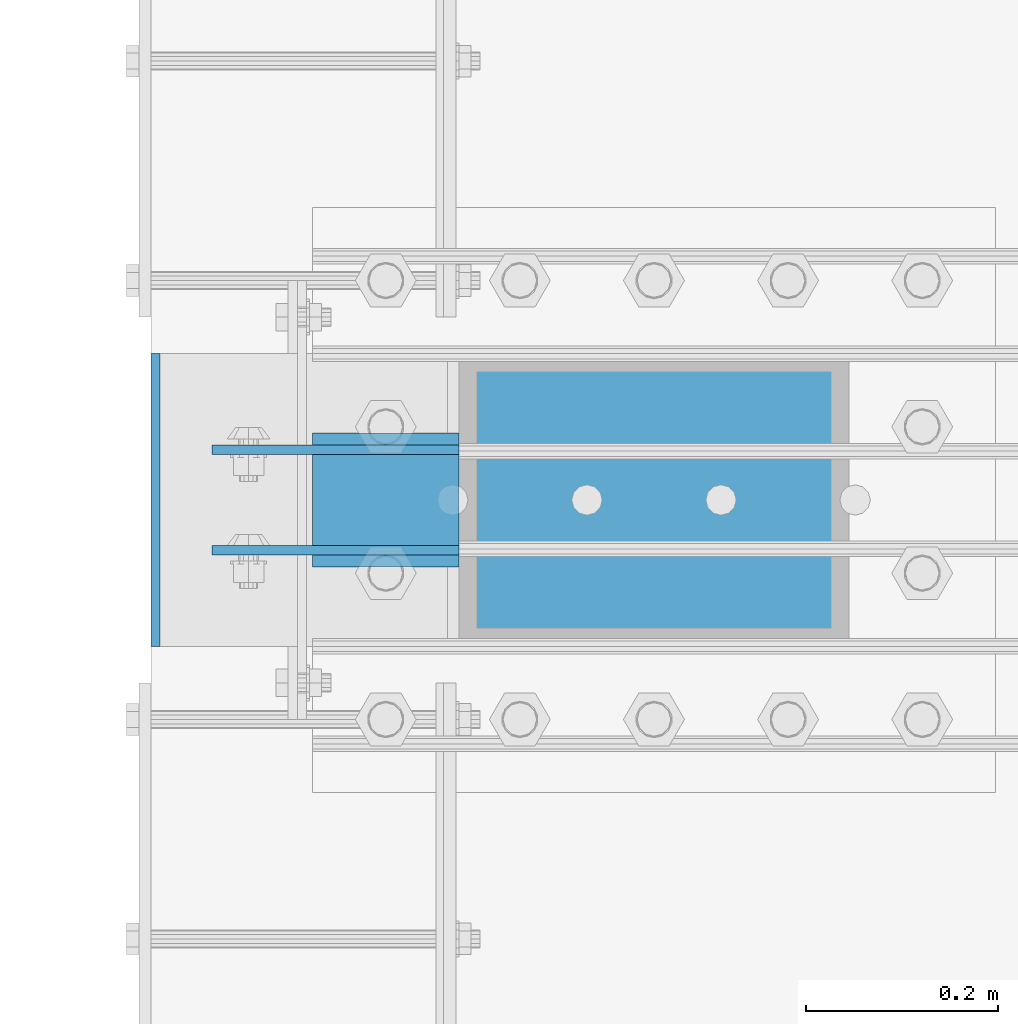
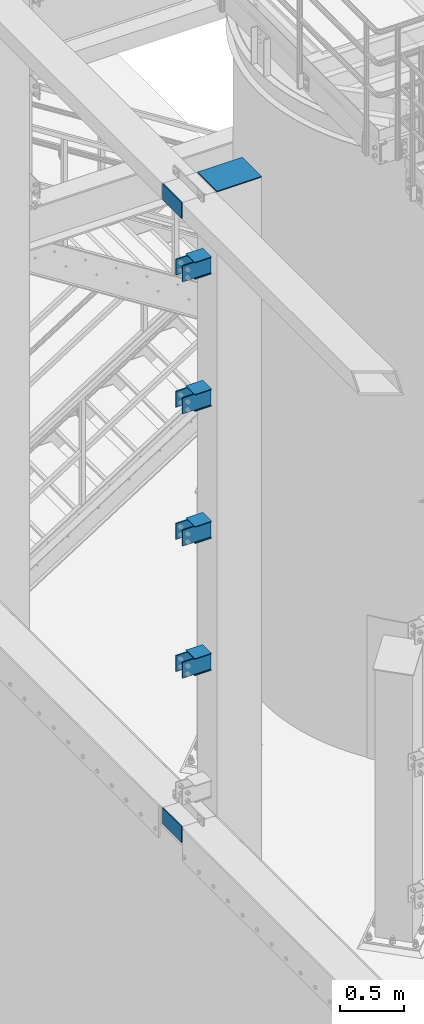
# One storey, part 1096 of 1876: 19 beams, 1 element without a shape of its own.
"""IFC2X3 building model written with IfcOpenShell, lengths in millimetres."""

from ifc_helpers import new_model, si_unit, frame, origin_with_axes, place, context, subcontext, project, spatial, faceted_brep, material, type_object, element, aggregate, save


model = new_model("IFC2X3")

# Units and contexts
model_context = context("Model", 3, precision=1e-05, world=origin_with_axes())
body_context = subcontext(model_context, "Body", "Model", "MODEL_VIEW")
ifc_project = project(units=[si_unit("LENGTHUNIT", "METRE", prefix="MILLI"), si_unit("AREAUNIT", "SQUARE_METRE"), si_unit("VOLUMEUNIT", "CUBIC_METRE"), si_unit("MASSUNIT", "GRAM", prefix="KILO"), si_unit("TIMEUNIT", "SECOND"), si_unit("PLANEANGLEUNIT", "RADIAN"), si_unit("SOLIDANGLEUNIT", "STERADIAN"), si_unit("THERMODYNAMICTEMPERATUREUNIT", "DEGREE_CELSIUS"), si_unit("LUMINOUSINTENSITYUNIT", "LUMEN")], contexts=[model_context])

# Site, building, storey
site_placement = place(None, origin_with_axes())
site = spatial("IfcSite", under=ifc_project, at=site_placement, CompositionType="ELEMENT")
building_placement = place(site_placement, origin_with_axes())
building = spatial("IfcBuilding", under=site, at=building_placement, Name="Undefined", CompositionType="ELEMENT")
storey_placement = place(building_placement, origin_with_axes())
storey = spatial("IfcBuildingStorey", under=building, at=storey_placement, Name="Undefined", CompositionType="ELEMENT", Elevation=0.0)

# Assembly, beams
assembly_placement = place(storey_placement, origin_with_axes())
assembly = element("IfcElementAssembly", 1, at=assembly_placement, inside=storey, Name="COLUMN", AssemblyPlace="NOTDEFINED", PredefinedType="RIGID_FRAME")
ifc_material = material(Name="STEEL/A36")
beam_type_1 = type_object("IfcBeamType", PredefinedType="NOTDEFINED")
beam_1_placement = place(assembly_placement, frame((28.5750000000013, -14479.5875, 6097.5875), z_axis=(0.0, 0.0, -1.0), x_axis=(-1.0, 0.0, 0.0)))
beam_1 = element("IfcBeam", 2, at=beam_1_placement, type_object=beam_type_1, material=ifc_material, Name="PLATE", context=body_context, shape_type="Brep", body=[
    faceted_brep([(0.0, 4.76249999999982, -76.1999999999998), (3.63797880709171e-12, 4.76249999999982, 76.1999969482422), (257.174999999999, 4.76249999999982, 76.1999999999998), (257.174999999999, 4.76249999999982, -76.1999999999998), (3.63797880709171e-12, -4.76249999999982, 76.1999969482422), (257.174999999999, -4.76249999999982, 76.1999999999998), (0.0, -4.76249999999982, -76.1999999999998), (257.174999999999, -4.76249999999982, -76.1999999999998)], [[[0, 1, 2, 3]], [[1, 4, 5, 2]], [[4, 6, 7, 5]], [[6, 0, 3, 7]], [[5, 7, 3, 2]], [[6, 4, 1, 0]]]),
])
beam_2_placement = place(assembly_placement, frame((28.5750000000013, -14479.5875, 7366.46302033333), z_axis=(0.0, 0.0, -1.0), x_axis=(-1.0, 0.0, 0.0)))
beam_2 = element("IfcBeam", 3, at=beam_2_placement, type_object=beam_type_1, material=ifc_material, Name="PLATE", context=body_context, shape_type="Brep", body=[
    faceted_brep([(0.0, 4.76249999999982, -76.1999999999998), (3.63797880709171e-12, 4.76249999999982, 76.1999969482422), (257.174999999999, 4.76249999999982, 76.1999999999998), (257.174999999999, 4.76249999999982, -76.1999999999998), (3.63797880709171e-12, -4.76249999999982, 76.1999969482422), (257.174999999999, -4.76249999999982, 76.1999999999998), (0.0, -4.76249999999982, -76.1999999999998), (257.174999999999, -4.76249999999982, -76.1999999999998)], [[[0, 1, 2, 3]], [[1, 4, 5, 2]], [[4, 6, 7, 5]], [[6, 0, 3, 7]], [[5, 7, 3, 2]], [[6, 4, 1, 0]]]),
])
beam_3_placement = place(assembly_placement, frame((28.5750000000013, -14479.5875, 8635.47083333333), z_axis=(0.0, 0.0, -1.0), x_axis=(-1.0, 0.0, 0.0)))
beam_3 = element("IfcBeam", 4, at=beam_3_placement, type_object=beam_type_1, material=ifc_material, Name="PLATE", context=body_context, shape_type="Brep", body=[
    faceted_brep([(0.0, 4.76249999999982, -76.1999999999998), (3.63797880709171e-12, 4.76249999999982, 76.1999969482422), (257.174999999999, 4.76249999999982, 76.1999999999998), (257.174999999999, 4.76249999999982, -76.1999999999998), (3.63797880709171e-12, -4.76249999999982, 76.1999969482422), (257.174999999999, -4.76249999999982, 76.1999999999998), (0.0, -4.76249999999982, -76.1999999999998), (257.174999999999, -4.76249999999982, -76.1999999999998)], [[[0, 1, 2, 3]], [[1, 4, 5, 2]], [[4, 6, 7, 5]], [[6, 0, 3, 7]], [[5, 7, 3, 2]], [[6, 4, 1, 0]]]),
])
beam_4_placement = place(assembly_placement, frame((28.5750000000013, -14479.5875, 9904.4125), z_axis=(0.0, 0.0, -1.0), x_axis=(-1.0, 0.0, 0.0)))
beam_4 = element("IfcBeam", 5, at=beam_4_placement, type_object=beam_type_1, material=ifc_material, Name="PLATE", context=body_context, shape_type="Brep", body=[
    faceted_brep([(0.0, 4.76249999999982, -76.1999999999998), (3.63797880709171e-12, 4.76249999999982, 76.1999969482422), (257.174999999999, 4.76249999999982, 76.1999999999998), (257.174999999999, 4.76249999999982, -76.1999999999998), (3.63797880709171e-12, -4.76249999999982, 76.1999969482422), (257.174999999999, -4.76249999999982, 76.1999999999998), (0.0, -4.76249999999982, -76.1999999999998), (257.174999999999, -4.76249999999982, -76.1999999999998)], [[[0, 1, 2, 3]], [[1, 4, 5, 2]], [[4, 6, 7, 5]], [[6, 0, 3, 7]], [[5, 7, 3, 2]], [[6, 4, 1, 0]]]),
])
beam_5_placement = place(assembly_placement, frame((28.5750000000013, -14374.8124984741, 6097.5875), z_axis=(0.0, 0.0, -1.0), x_axis=(-1.0, 0.0, 0.0)))
beam_5 = element("IfcBeam", 6, at=beam_5_placement, type_object=beam_type_1, material=ifc_material, Name="PLATE", context=body_context, shape_type="Brep", body=[
    faceted_brep([(0.0, 4.76249999999982, -76.1999999999998), (3.63797880709171e-12, 4.76249999999982, 76.1999969482422), (257.174999999999, 4.76249999999982, 76.1999999999998), (257.174999999999, 4.76249999999982, -76.1999999999998), (3.63797880709171e-12, -4.76249999999982, 76.1999969482422), (257.174999999999, -4.76249999999982, 76.1999999999998), (0.0, -4.76249999999982, -76.1999999999998), (257.174999999999, -4.76249999999982, -76.1999999999998)], [[[0, 1, 2, 3]], [[1, 4, 5, 2]], [[4, 6, 7, 5]], [[6, 0, 3, 7]], [[5, 7, 3, 2]], [[6, 4, 1, 0]]]),
])
beam_6_placement = place(assembly_placement, frame((28.5750000000013, -14374.8124984741, 7366.46302033333), z_axis=(0.0, 0.0, -1.0), x_axis=(-1.0, 0.0, 0.0)))
beam_6 = element("IfcBeam", 7, at=beam_6_placement, type_object=beam_type_1, material=ifc_material, Name="PLATE", context=body_context, shape_type="Brep", body=[
    faceted_brep([(0.0, 4.76249999999982, -76.1999999999998), (3.63797880709171e-12, 4.76249999999982, 76.1999969482422), (257.174999999999, 4.76249999999982, 76.1999999999998), (257.174999999999, 4.76249999999982, -76.1999999999998), (3.63797880709171e-12, -4.76249999999982, 76.1999969482422), (257.174999999999, -4.76249999999982, 76.1999999999998), (0.0, -4.76249999999982, -76.1999999999998), (257.174999999999, -4.76249999999982, -76.1999999999998)], [[[0, 1, 2, 3]], [[1, 4, 5, 2]], [[4, 6, 7, 5]], [[6, 0, 3, 7]], [[5, 7, 3, 2]], [[6, 4, 1, 0]]]),
])
beam_7_placement = place(assembly_placement, frame((28.5750000000013, -14374.8124984741, 8635.47083333333), z_axis=(0.0, 0.0, -1.0), x_axis=(-1.0, 0.0, 0.0)))
beam_7 = element("IfcBeam", 8, at=beam_7_placement, type_object=beam_type_1, material=ifc_material, Name="PLATE", context=body_context, shape_type="Brep", body=[
    faceted_brep([(0.0, 4.76249999999982, -76.1999999999998), (3.63797880709171e-12, 4.76249999999982, 76.1999969482422), (257.174999999999, 4.76249999999982, 76.1999999999998), (257.174999999999, 4.76249999999982, -76.1999999999998), (3.63797880709171e-12, -4.76249999999982, 76.1999969482422), (257.174999999999, -4.76249999999982, 76.1999999999998), (0.0, -4.76249999999982, -76.1999999999998), (257.174999999999, -4.76249999999982, -76.1999999999998)], [[[0, 1, 2, 3]], [[1, 4, 5, 2]], [[4, 6, 7, 5]], [[6, 0, 3, 7]], [[5, 7, 3, 2]], [[6, 4, 1, 0]]]),
])
beam_8_placement = place(assembly_placement, frame((28.5750000000013, -14374.8124984741, 9904.4125), z_axis=(0.0, 0.0, -1.0), x_axis=(-1.0, 0.0, 0.0)))
beam_8 = element("IfcBeam", 9, at=beam_8_placement, type_object=beam_type_1, material=ifc_material, Name="PLATE", context=body_context, shape_type="Brep", body=[
    faceted_brep([(0.0, 4.76249999999982, -76.1999999999998), (3.63797880709171e-12, 4.76249999999982, 76.1999969482422), (257.174999999999, 4.76249999999982, 76.1999999999998), (257.174999999999, 4.76249999999982, -76.1999999999998), (3.63797880709171e-12, -4.76249999999982, 76.1999969482422), (257.174999999999, -4.76249999999982, 76.1999999999998), (0.0, -4.76249999999982, -76.1999999999998), (257.174999999999, -4.76249999999982, -76.1999999999998)], [[[0, 1, 2, 3]], [[1, 4, 5, 2]], [[4, 6, 7, 5]], [[6, 0, 3, 7]], [[5, 7, 3, 2]], [[6, 4, 1, 0]]]),
])
beam_9_placement = place(assembly_placement, frame((-287.3375, -14579.6, 4597.4), z_axis=(0.0, 0.0, 1.0), x_axis=(0.0, 1.0, 0.0)))
beam_9 = element("IfcBeam", 10, at=beam_9_placement, type_object=beam_type_1, material=ifc_material, Name="PLATE", context=body_context, shape_type="Brep", body=[
    faceted_brep([(0.0, 4.76249999999982, -76.1999999999998), (3.63797880709171e-12, 4.76249999999982, 76.1999969482422), (304.799999999999, 4.76250000000073, 76.1999999999998), (304.799999999999, 4.76250000000073, -76.1999999999998), (3.63797880709171e-12, -4.76249999999982, 76.1999969482422), (304.799999999999, -4.76250000000073, 76.1999999999998), (0.0, -4.76249999999982, -76.1999999999998), (304.799999999999, -4.76250000000073, -76.1999999999998)], [[[0, 1, 2, 3]], [[1, 4, 5, 2]], [[4, 6, 7, 5]], [[6, 0, 3, 7]], [[5, 7, 3, 2]], [[6, 4, 1, 0]]]),
])
beam_10_placement = place(assembly_placement, frame((-287.337500000002, -14579.6, 10591.8), z_axis=(0.0, 0.0, 1.0), x_axis=(0.0, 1.0, 0.0)))
beam_10 = element("IfcBeam", 11, at=beam_10_placement, type_object=beam_type_1, material=ifc_material, Name="PLATE", context=body_context, shape_type="Brep", body=[
    faceted_brep([(0.0, 4.76249999999982, -76.1999999999998), (3.63797880709171e-12, 4.76249999999982, 76.1999969482422), (304.799999999999, 4.76250000000073, 76.1999999999998), (304.799999999999, 4.76250000000073, -76.1999999999998), (3.63797880709171e-12, -4.76249999999982, 76.1999969482422), (304.799999999999, -4.76250000000073, 76.1999999999998), (0.0, -4.76249999999982, -76.1999999999998), (304.799999999999, -4.76250000000073, -76.1999999999998)], [[[0, 1, 2, 3]], [[1, 4, 5, 2]], [[4, 6, 7, 5]], [[6, 0, 3, 7]], [[5, 7, 3, 2]], [[6, 4, 1, 0]]]),
])
beam_type_2 = type_object("IfcBeamType", PredefinedType="NOTDEFINED")
beam_11_placement = place(assembly_placement, frame((28.5750000000032, -14427.2, 9825.0375), z_axis=(0.0, -1.0, 0.0), x_axis=(-1.0, 0.0, 0.0)))
beam_11 = element("IfcBeam", 12, at=beam_11_placement, type_object=beam_type_2, material=ifc_material, Name="PLATE", context=body_context, shape_type="Brep", body=[
    faceted_brep([(0.0, 3.17500000000018, -69.8499999999999), (0.0, 3.17500000000018, 69.8499999999999), (152.400000000001, 3.17500000000018, 69.8499999999999), (152.400000000001, 3.17500000000018, -69.8499999999999), (0.0, -3.17500000000018, 69.8499999999999), (152.400000000001, -3.17500000000018, 69.8499999999999), (0.0, -3.17500000000018, -69.8499999999999), (152.400000000001, -3.17500000000018, -69.8499999999999)], [[[0, 1, 2, 3]], [[1, 4, 5, 2]], [[4, 6, 7, 5]], [[6, 0, 3, 7]], [[5, 7, 3, 2]], [[6, 4, 1, 0]]]),
])
beam_12_placement = place(assembly_placement, frame((28.5749999999986, -14427.2, 9983.7875), z_axis=(0.0, -1.0, 0.0), x_axis=(-1.0, 0.0, 0.0)))
beam_12 = element("IfcBeam", 13, at=beam_12_placement, type_object=beam_type_2, material=ifc_material, Name="PLATE", context=body_context, shape_type="Brep", body=[
    faceted_brep([(0.0, 3.17500000000018, -69.8499999999999), (0.0, 3.17500000000018, 69.8499999999999), (152.400000000001, 3.17500000000018, 69.8499999999999), (152.400000000001, 3.17500000000018, -69.8499999999999), (0.0, -3.17500000000018, 69.8499999999999), (152.400000000001, -3.17500000000018, 69.8499999999999), (0.0, -3.17500000000018, -69.8499999999999), (152.400000000001, -3.17500000000018, -69.8499999999999)], [[[0, 1, 2, 3]], [[1, 4, 5, 2]], [[4, 6, 7, 5]], [[6, 0, 3, 7]], [[5, 7, 3, 2]], [[6, 4, 1, 0]]]),
])
beam_13_placement = place(assembly_placement, frame((28.5750000000031, -14427.2, 8556.09583333333), z_axis=(0.0, -1.0, 0.0), x_axis=(-1.0, 0.0, 0.0)))
beam_13 = element("IfcBeam", 14, at=beam_13_placement, type_object=beam_type_2, material=ifc_material, Name="PLATE", context=body_context, shape_type="Brep", body=[
    faceted_brep([(0.0, 3.17500000000018, -69.8499999999999), (0.0, 3.17500000000018, 69.8499999999999), (152.400000000001, 3.17500000000018, 69.8499999999999), (152.400000000001, 3.17500000000018, -69.8499999999999), (0.0, -3.17500000000018, 69.8499999999999), (152.400000000001, -3.17500000000018, 69.8499999999999), (0.0, -3.17500000000018, -69.8499999999999), (152.400000000001, -3.17500000000018, -69.8499999999999)], [[[0, 1, 2, 3]], [[1, 4, 5, 2]], [[4, 6, 7, 5]], [[6, 0, 3, 7]], [[5, 7, 3, 2]], [[6, 4, 1, 0]]]),
])
beam_14_placement = place(assembly_placement, frame((28.5749999999986, -14427.2, 8714.84583333334), z_axis=(0.0, -1.0, 0.0), x_axis=(-1.0, 0.0, 0.0)))
beam_14 = element("IfcBeam", 15, at=beam_14_placement, type_object=beam_type_2, material=ifc_material, Name="PLATE", context=body_context, shape_type="Brep", body=[
    faceted_brep([(0.0, 3.17500000000018, -69.8499999999999), (0.0, 3.17500000000018, 69.8499999999999), (152.400000000001, 3.17500000000018, 69.8499999999999), (152.400000000001, 3.17500000000018, -69.8499999999999), (0.0, -3.17500000000018, 69.8499999999999), (152.400000000001, -3.17500000000018, 69.8499999999999), (0.0, -3.17500000000018, -69.8499999999999), (152.400000000001, -3.17500000000018, -69.8499999999999)], [[[0, 1, 2, 3]], [[1, 4, 5, 2]], [[4, 6, 7, 5]], [[6, 0, 3, 7]], [[5, 7, 3, 2]], [[6, 4, 1, 0]]]),
])
beam_15_placement = place(assembly_placement, frame((28.5750000000031, -14427.2, 7287.08802033333), z_axis=(0.0, -1.0, 0.0), x_axis=(-1.0, 0.0, 0.0)))
beam_15 = element("IfcBeam", 16, at=beam_15_placement, type_object=beam_type_2, material=ifc_material, Name="PLATE", context=body_context, shape_type="Brep", body=[
    faceted_brep([(0.0, 3.17500000000018, -69.8499999999999), (0.0, 3.17500000000018, 69.8499999999999), (152.400000000001, 3.17500000000018, 69.8499999999999), (152.400000000001, 3.17500000000018, -69.8499999999999), (0.0, -3.17500000000018, 69.8499999999999), (152.400000000001, -3.17500000000018, 69.8499999999999), (0.0, -3.17500000000018, -69.8499999999999), (152.400000000001, -3.17500000000018, -69.8499999999999)], [[[0, 1, 2, 3]], [[1, 4, 5, 2]], [[4, 6, 7, 5]], [[6, 0, 3, 7]], [[5, 7, 3, 2]], [[6, 4, 1, 0]]]),
])
beam_16_placement = place(assembly_placement, frame((28.5749999999986, -14427.2, 7445.83802033334), z_axis=(0.0, -1.0, 0.0), x_axis=(-1.0, 0.0, 0.0)))
beam_16 = element("IfcBeam", 17, at=beam_16_placement, type_object=beam_type_2, material=ifc_material, Name="PLATE", context=body_context, shape_type="Brep", body=[
    faceted_brep([(0.0, 3.17500000000018, -69.8499999999999), (0.0, 3.17500000000018, 69.8499999999999), (152.400000000001, 3.17500000000018, 69.8499999999999), (152.400000000001, 3.17500000000018, -69.8499999999999), (0.0, -3.17500000000018, 69.8499999999999), (152.400000000001, -3.17500000000018, 69.8499999999999), (0.0, -3.17500000000018, -69.8499999999999), (152.400000000001, -3.17500000000018, -69.8499999999999)], [[[0, 1, 2, 3]], [[1, 4, 5, 2]], [[4, 6, 7, 5]], [[6, 0, 3, 7]], [[5, 7, 3, 2]], [[6, 4, 1, 0]]]),
])
beam_17_placement = place(assembly_placement, frame((28.5750000000031, -14427.2, 6018.2125), z_axis=(0.0, -1.0, 0.0), x_axis=(-1.0, 0.0, 0.0)))
beam_17 = element("IfcBeam", 18, at=beam_17_placement, type_object=beam_type_2, material=ifc_material, Name="PLATE", context=body_context, shape_type="Brep", body=[
    faceted_brep([(0.0, 3.17500000000018, -69.8499999999999), (0.0, 3.17500000000018, 69.8499999999999), (152.400000000001, 3.17500000000018, 69.8499999999999), (152.400000000001, 3.17500000000018, -69.8499999999999), (0.0, -3.17500000000018, 69.8499999999999), (152.400000000001, -3.17500000000018, 69.8499999999999), (0.0, -3.17500000000018, -69.8499999999999), (152.400000000001, -3.17500000000018, -69.8499999999999)], [[[0, 1, 2, 3]], [[1, 4, 5, 2]], [[4, 6, 7, 5]], [[6, 0, 3, 7]], [[5, 7, 3, 2]], [[6, 4, 1, 0]]]),
])
beam_18_placement = place(assembly_placement, frame((28.5749999999986, -14427.2, 6176.9625), z_axis=(0.0, -1.0, 0.0), x_axis=(-1.0, 0.0, 0.0)))
beam_18 = element("IfcBeam", 19, at=beam_18_placement, type_object=beam_type_2, material=ifc_material, Name="PLATE", context=body_context, shape_type="Brep", body=[
    faceted_brep([(0.0, 3.17500000000018, -69.8499999999999), (0.0, 3.17500000000018, 69.8499999999999), (152.400000000001, 3.17500000000018, 69.8499999999999), (152.400000000001, 3.17500000000018, -69.8499999999999), (0.0, -3.17500000000018, 69.8499999999999), (152.400000000001, -3.17500000000018, 69.8499999999999), (0.0, -3.17500000000018, -69.8499999999999), (152.400000000001, -3.17500000000018, -69.8499999999999)], [[[0, 1, 2, 3]], [[1, 4, 5, 2]], [[4, 6, 7, 5]], [[6, 0, 3, 7]], [[5, 7, 3, 2]], [[6, 4, 1, 0]]]),
])
beam_type_3 = type_object("IfcBeamType", PredefinedType="NOTDEFINED")
beam_19_placement = place(assembly_placement, frame((434.974999999999, -14427.2, 10663.2375), z_axis=(0.0, 1.0, 0.0), x_axis=(-1.0, 0.0, 0.0)))
beam_19 = element("IfcBeam", 20, at=beam_19_placement, type_object=beam_type_3, material=ifc_material, Name="PLATE", context=body_context, shape_type="Brep", body=[
    faceted_brep([(0.0, 4.76250000000073, -152.4), (0.0, 4.76250000000073, 152.4), (406.400000000001, 4.76250000000073, 152.4), (406.400000000001, 4.76250000000073, -152.4), (0.0, -4.76250000000073, 152.4), (406.400000000001, -4.76250000000073, 152.4), (0.0, -4.76250000000073, -152.4), (406.400000000001, -4.76250000000073, -152.4)], [[[0, 1, 2, 3]], [[1, 4, 5, 2]], [[4, 6, 7, 5]], [[6, 0, 3, 7]], [[5, 7, 3, 2]], [[6, 4, 1, 0]]]),
])
aggregate(assembly, [beam_11, beam_12, beam_13, beam_14, beam_15, beam_16, beam_17, beam_18, beam_1, beam_2, beam_3, beam_4, beam_5, beam_6, beam_7, beam_8, beam_19, beam_9, beam_10])

save(model, "model.ifc")
